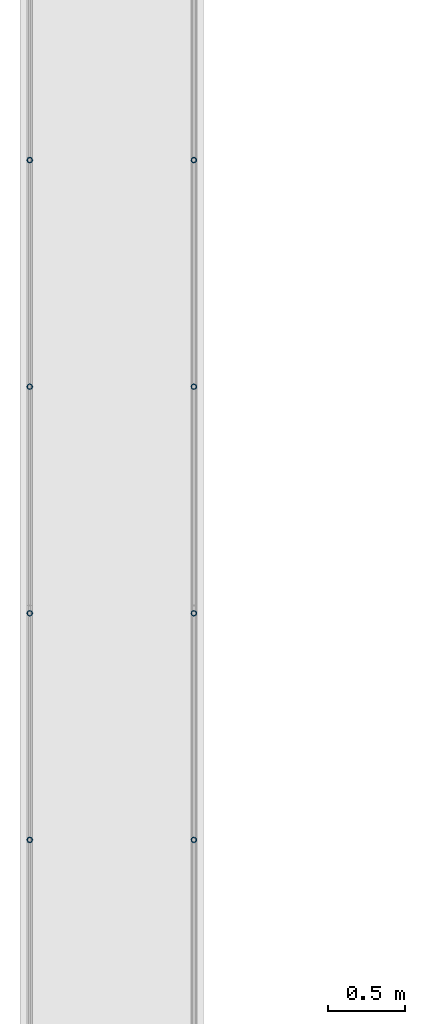
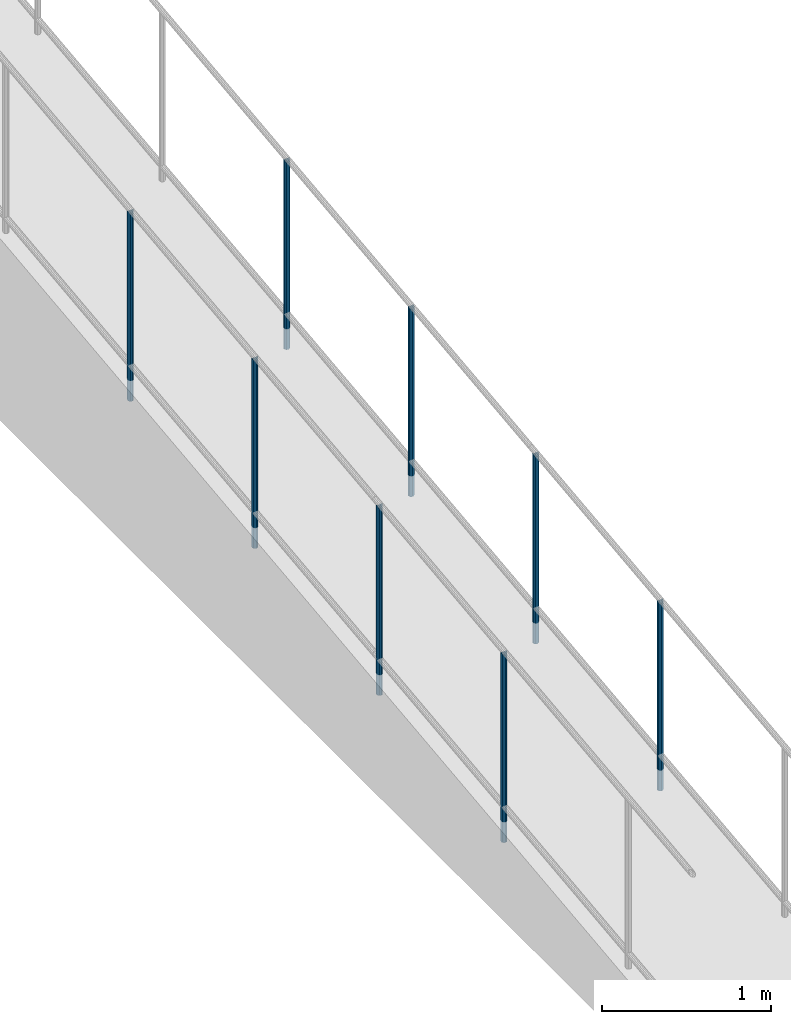
# One storey, part 874 of 1763: 8 columns, 4 elements without a shape of their own.
"""IFC2X3 building model written with IfcOpenShell, lengths in millimetres."""

from ifc_helpers import new_model, si_unit, frame, origin_with_axes, place, context, subcontext, project, spatial, faceted_brep, material, type_object, element, aggregate, save


model = new_model("IFC2X3")

# Units and contexts
model_context = context("Model", 3, precision=1e-05, world=origin_with_axes())
body_context = subcontext(model_context, "Body", "Model", "MODEL_VIEW")
ifc_project = project(units=[si_unit("LENGTHUNIT", "METRE", prefix="MILLI"), si_unit("AREAUNIT", "SQUARE_METRE"), si_unit("VOLUMEUNIT", "CUBIC_METRE"), si_unit("MASSUNIT", "GRAM", prefix="KILO"), si_unit("TIMEUNIT", "SECOND"), si_unit("PLANEANGLEUNIT", "RADIAN"), si_unit("SOLIDANGLEUNIT", "STERADIAN"), si_unit("THERMODYNAMICTEMPERATUREUNIT", "DEGREE_CELSIUS"), si_unit("LUMINOUSINTENSITYUNIT", "LUMEN")], contexts=[model_context])

# Site, building, storey
site_placement = place(None, origin_with_axes())
site = spatial("IfcSite", under=ifc_project, at=site_placement, CompositionType="ELEMENT")
building_placement = place(site_placement, origin_with_axes())
building = spatial("IfcBuilding", under=site, at=building_placement, Name="Undefined", CompositionType="ELEMENT")
storey_placement = place(building_placement, origin_with_axes())
storey = spatial("IfcBuildingStorey", under=building, at=storey_placement, Name="Undefined", CompositionType="ELEMENT", Elevation=0.0)

# Assembly, columns
assembly_1_placement = place(storey_placement, origin_with_axes())
assembly_1 = element("IfcElementAssembly", 1, at=assembly_1_placement, inside=storey, Name="GUARDRAIL", AssemblyPlace="NOTDEFINED", PredefinedType="RIGID_FRAME")
ifc_material = material(Name="STEEL/A513")
column_type = type_object("IfcColumnType", PredefinedType="NOTDEFINED")
column_1_placement = place(assembly_1_placement, frame((-97200.6527017878, -5416.76266955813, 4407.28954874992), z_axis=(0.0, -0.999999999989044, 4.68099999989136e-06), x_axis=(0.0, 4.68100000009712e-06, 0.999999999989044)))
column_1 = element("IfcColumn", 2, at=column_1_placement, type_object=column_type, material=ifc_material, Name="POST TUBE", context=body_context, shape_type="Brep", body=[
    faceted_brep([(1371.60074802696, 19.0500000000029, -4.95674612466246e-10), (1360.84881750874, 16.4977839420899, 9.52499999994143), (1363.03561091082, 16.4977839420899, -9.52500000005693), (1352.86103134268, -7.14375000000291, 12.3733379565128), (1350.71456778439, 0.0, 14.2874999999422), (1350.16786943387, 0.0, 19.0499999999411), (1353.02982084493, -9.52499999999418, 16.4977839420362), (1353.77662467995, -9.52499999999418, 9.99208795651248), (1353.77662467995, 9.52499999999418, 9.99208795651248), (1353.02982084493, 9.52499999999418, 16.4977839420362), (1352.86103134268, 7.14375000000291, 12.3733379565128), (1356.97063515909, 12.3733379565674, 7.14374999994197), (1359.71741517087, 14.2875000000058, -5.82076609134674e-11), (1358.61073021065, 12.3733379565674, -7.14375000005748), (1356.07065428797, 9.52499999999418, -9.99208795662707), (1356.81745812299, 9.52499999999418, -16.4977839421499), (1355.70175930123, 7.14375000000291, -12.3733379566265), (1353.99475788751, 0.0, -14.2875000000577), (1354.54145623803, 0.0, -19.0500000000566), (1355.70175930123, -7.14375000000291, -12.3733379566265), (1356.07065428797, -9.52499999999418, -9.99208795662707), (1356.81745812299, -9.52499999999418, -16.4977839421499), (1371.53068898859, -19.0500000000029, -0.00804413668356574), (1363.03561091082, -16.4977839420899, -9.52500000005693), (1360.84881750874, -16.4977839420899, 9.52499999994143), (1358.61073021064, -12.3733379565674, -7.14375000005748), (1359.71741517087, -14.2875000000058, -5.82076609134674e-11), (1356.97063515908, -12.3733379565674, 7.14374999994197), (0.0, -16.4977839420899, -9.52500000000146), (0.0, -9.52499999999418, -16.4977839420935), (1.45519152283669e-11, 1.81898940354586e-12, -19.0499999999993), (0.0, 9.52499999999418, -16.4977839420935), (0.0, 16.4977839420899, -9.52500000000146), (0.0, 19.0500000000029, 0.0), (0.0, 16.4977839420899, 9.52500000000146), (0.0, 9.52499999999418, 16.4977839420935), (1.45519152283669e-11, 1.81898940354586e-12, 19.0499999999993), (0.0, -9.52499999999418, 16.4977839420935), (0.0, -16.4977839420899, 9.52500000000146), (0.0, -19.0500000000029, 0.0), (0.0, -12.3733379565674, -7.14374999999927), (0.0, -7.14375000000291, -12.373337956571), (0.0, 0.0, -14.2874999999985), (0.0, 7.14375000000291, -12.373337956571), (0.0, 12.3733379565674, -7.14374999999927), (0.0, 14.2875000000058, 0.0), (0.0, 12.3733379565674, 7.14374999999927), (0.0, 7.14375000000291, 12.373337956571), (0.0, 0.0, 14.2874999999985), (0.0, -7.14375000000291, 12.373337956571), (0.0, -12.3733379565674, 7.14374999999927), (0.0, -14.2875000000058, 0.0)], [[[0, 1, 2]], [[3, 4, 5, 6, 7]], [[8, 9, 5, 4, 10]], [[2, 1, 9, 8, 11, 12, 13, 14, 15]], [[15, 14, 16, 17, 18]], [[18, 17, 19, 20, 21]], [[22, 23, 24]], [[21, 20, 25, 26, 27, 7, 6, 24, 23]], [[28, 29, 21, 23]], [[29, 30, 18, 21]], [[30, 31, 15, 18]], [[31, 32, 2, 15]], [[32, 33, 0, 2]], [[33, 34, 1, 0]], [[34, 35, 9, 1]], [[35, 36, 5, 9]], [[36, 37, 6, 5]], [[37, 38, 24, 6]], [[38, 39, 22, 24]], [[39, 28, 23, 22]], [[38, 37, 36, 35, 34, 33, 32, 31, 30, 29, 28, 39], [40, 41, 42, 43, 44, 45, 46, 47, 48, 49, 50, 51]], [[40, 51, 26, 25]], [[19, 41, 40, 25, 20]], [[42, 41, 19, 17]], [[43, 42, 17, 16]], [[44, 43, 16, 14, 13]], [[45, 44, 13, 12]], [[46, 45, 12, 11]], [[10, 47, 46, 11, 8]], [[48, 47, 10, 4]], [[49, 48, 4, 3]], [[50, 49, 3, 7, 27]], [[51, 50, 27, 26]]]),
])
column_2_placement = place(assembly_1_placement, frame((-97200.6527017878, -6889.96267103608, 4238.14864948887), z_axis=(0.0, -0.999999999989044, 4.68099999989136e-06), x_axis=(0.0, 4.68100000009712e-06, 0.999999999989044)))
column_2 = element("IfcColumn", 3, at=column_2_placement, type_object=column_type, material=ifc_material, Name="POST TUBE", context=body_context, shape_type="Brep", body=[
    faceted_brep([(1371.60074802696, 19.0500000000029, -4.95674612466246e-10), (1360.88493927643, 16.4977839420899, 9.52499999985503), (1363.07173256271, 16.4977839420899, -9.52500000014425), (1352.89715313297, -7.14375000000291, 12.3733379564264), (1350.75068958764, 0.0, 14.2874999998558), (1350.20399126607, 0.0, 19.0499999998547), (1353.06594265984, -9.52499999999418, 16.497783941948), (1353.81274645531, -9.52499999999418, 9.99208795642517), (1353.81274645531, 9.52499999999418, 9.99208795642517), (1353.06594265984, 9.52499999999418, 16.497783941948), (1352.89715313297, 7.14375000000291, 12.3733379564264), (1357.00675691517, 12.3733379565674, 7.14374999985466), (1359.7535368822, 14.2875000000058, -1.43700162880123e-10), (1358.64685187987, 12.3733379565674, -7.14375000014297), (1356.10677594185, 9.52499999999418, -9.99208795671348), (1356.85357973732, 9.52499999999418, -16.4977839422363), (1355.73788094108, 7.14375000000291, -12.3733379567129), (1354.03087951705, 0.0, -14.2875000001432), (1354.57757783861, 0.0, -19.050000000143), (1355.73788094107, -7.14375000000291, -12.3733379567129), (1356.10677594185, -9.52499999999418, -9.99208795671348), (1356.85357973732, -9.52499999999418, -16.4977839422363), (1371.56634088451, -19.0500000000029, -0.00395146479149844), (1363.07173256271, -16.4977839420899, -9.52500000014425), (1360.88493927643, -16.4977839420899, 9.52499999985503), (1358.64685187987, -12.3733379565674, -7.14375000014297), (1359.75353688219, -14.2875000000058, -1.43700162880123e-10), (1357.00675691516, -12.3733379565674, 7.14374999985466), (0.0, -16.4977839420899, -9.52500000000146), (0.0, -9.52499999999418, -16.4977839420935), (1.45519152283669e-11, 1.81898940354586e-12, -19.0499999999993), (0.0, 9.52499999999418, -16.4977839420935), (0.0, 16.4977839420899, -9.52500000000146), (0.0, 19.0500000000029, 0.0), (0.0, 16.4977839420899, 9.52500000000146), (0.0, 9.52499999999418, 16.4977839420935), (1.45519152283669e-11, 1.81898940354586e-12, 19.0499999999993), (0.0, -9.52499999999418, 16.4977839420935), (0.0, -16.4977839420899, 9.52500000000146), (0.0, -19.0500000000029, 0.0), (0.0, -12.3733379565674, -7.14374999999927), (0.0, -7.14375000000291, -12.373337956571), (0.0, 0.0, -14.2874999999985), (0.0, 7.14375000000291, -12.373337956571), (0.0, 12.3733379565674, -7.14374999999927), (0.0, 14.2875000000058, 0.0), (0.0, 12.3733379565674, 7.14374999999927), (0.0, 7.14375000000291, 12.373337956571), (0.0, 0.0, 14.2874999999985), (0.0, -7.14375000000291, 12.373337956571), (0.0, -12.3733379565674, 7.14374999999927), (0.0, -14.2875000000058, 0.0)], [[[0, 1, 2]], [[3, 4, 5, 6, 7]], [[8, 9, 5, 4, 10]], [[2, 1, 9, 8, 11, 12, 13, 14, 15]], [[15, 14, 16, 17, 18]], [[18, 17, 19, 20, 21]], [[22, 23, 24]], [[21, 20, 25, 26, 27, 7, 6, 24, 23]], [[28, 29, 21, 23]], [[29, 30, 18, 21]], [[30, 31, 15, 18]], [[31, 32, 2, 15]], [[32, 33, 0, 2]], [[33, 34, 1, 0]], [[34, 35, 9, 1]], [[35, 36, 5, 9]], [[36, 37, 6, 5]], [[37, 38, 24, 6]], [[38, 39, 22, 24]], [[39, 28, 23, 22]], [[38, 37, 36, 35, 34, 33, 32, 31, 30, 29, 28, 39], [40, 41, 42, 43, 44, 45, 46, 47, 48, 49, 50, 51]], [[40, 51, 26, 25]], [[19, 41, 40, 25, 20]], [[42, 41, 19, 17]], [[43, 42, 17, 16]], [[44, 43, 16, 14, 13]], [[45, 44, 13, 12]], [[46, 45, 12, 11]], [[10, 47, 46, 11, 8]], [[48, 47, 10, 4]], [[49, 48, 4, 3]], [[50, 49, 3, 7, 27]], [[51, 50, 27, 26]]]),
])
aggregate(assembly_1, [column_1, column_2])

assembly_2_placement = place(storey_placement, origin_with_axes())
assembly_2 = element("IfcElementAssembly", 4, at=assembly_2_placement, inside=storey, Name="GUARDRAIL", AssemblyPlace="NOTDEFINED", PredefinedType="RIGID_FRAME")
column_3_placement = place(assembly_2_placement, frame((-97200.6527017878, -8363.16267251402, 4069.00775022782), z_axis=(0.0, -0.999999999989044, 4.68099999989136e-06), x_axis=(0.0, 4.68100000009712e-06, 0.999999999989044)))
column_3 = element("IfcColumn", 5, at=column_3_placement, type_object=column_type, material=ifc_material, Name="POST TUBE", context=body_context, shape_type="Brep", body=[
    faceted_brep([(1371.60074802696, 19.0500000000029, -4.95674612466246e-10), (1360.91954353543, 16.4977839420899, 9.52499999992688), (1363.1068023618, 16.4977839420899, -9.52500000007285), (1352.93166657158, -7.14375000000291, 12.3733379564974), (1350.78515091293, 0.0, 14.2874999999276), (1350.23833620634, 0.0, 19.0499999999279), (1353.10035708436, -9.52499999999418, 16.4977839420208), (1353.84731986472, -9.52499999997963, 9.99208795651202), (1353.84731986473, 9.52500000000873, 9.99208795648292), (1353.10035708436, 9.52499999999418, 16.4977839420208), (1352.93166657157, 7.14375000000291, 12.3733379564974), (1357.04140787087, 12.3733379565674, 7.14374999992697), (1359.7883677507, 14.2875000000058, -7.27595761418343e-11), (1358.68185199063, 12.3733379565674, -7.14375000007294), (1356.14183772056, 9.52500000000873, -9.99208795662844), (1356.88880050093, 9.52499999999418, -16.4977839421663), (1355.77299913398, 7.14375000000291, -12.3733379566434), (1354.06603915248, 0.0, -14.2875000000727), (1354.61285385908, 0.0, -19.0500000000725), (1355.77299913399, -7.14375000000291, -12.3733379566434), (1356.14183772056, -9.52499999997963, -9.992087956658), (1356.88880050093, -9.52499999999418, -16.4977839421663), (1371.60075086449, -19.0499999999884, 1.21417542686686e-10), (1363.1068023618, -16.4977839420899, -9.52500000007285), (1360.91954353543, -16.4977839420899, 9.52499999992688), (1358.68185199066, -12.3733379565674, -7.14375000007294), (1359.78836775073, -14.2875000000058, -7.27595761418343e-11), (1357.0414078709, -12.3733379565674, 7.14374999992697), (0.0, -16.4977839420899, -9.52500000000146), (0.0, -9.52499999999418, -16.4977839420935), (1.45519152283669e-11, 1.81898940354586e-12, -19.0499999999993), (0.0, 9.52499999999418, -16.4977839420935), (0.0, 16.4977839420899, -9.52500000000146), (0.0, 19.0500000000029, 0.0), (0.0, 16.4977839420899, 9.52500000000146), (0.0, 9.52499999999418, 16.4977839420935), (1.45519152283669e-11, 1.81898940354586e-12, 19.0499999999993), (0.0, -9.52499999999418, 16.4977839420935), (0.0, -16.4977839420899, 9.52500000000146), (0.0, -19.0500000000029, 0.0), (0.0, -12.3733379565674, -7.14374999999927), (0.0, -7.14375000000291, -12.373337956571), (0.0, 0.0, -14.2874999999985), (0.0, 7.14375000000291, -12.373337956571), (0.0, 12.3733379565674, -7.14374999999927), (0.0, 14.2875000000058, 0.0), (0.0, 12.3733379565674, 7.14374999999927), (0.0, 7.14375000000291, 12.373337956571), (0.0, 0.0, 14.2874999999985), (0.0, -7.14375000000291, 12.373337956571), (0.0, -12.3733379565674, 7.14374999999927), (0.0, -14.2875000000058, 0.0)], [[[0, 1, 2]], [[3, 4, 5, 6, 7]], [[8, 9, 5, 4, 10]], [[2, 1, 9, 8, 11, 12, 13, 14, 15]], [[15, 14, 16, 17, 18]], [[18, 17, 19, 20, 21]], [[22, 23, 24]], [[21, 20, 25, 26, 27, 7, 6, 24, 23]], [[28, 29, 21, 23]], [[29, 30, 18, 21]], [[30, 31, 15, 18]], [[31, 32, 2, 15]], [[32, 33, 0, 2]], [[33, 34, 1, 0]], [[34, 35, 9, 1]], [[35, 36, 5, 9]], [[36, 37, 6, 5]], [[37, 38, 24, 6]], [[38, 39, 22, 24]], [[39, 28, 23, 22]], [[38, 37, 36, 35, 34, 33, 32, 31, 30, 29, 28, 39], [40, 41, 42, 43, 44, 45, 46, 47, 48, 49, 50, 51]], [[40, 51, 26, 25]], [[19, 41, 40, 25, 20]], [[42, 41, 19, 17]], [[43, 42, 17, 16]], [[44, 43, 16, 14, 13]], [[45, 44, 13, 12]], [[46, 45, 12, 11]], [[10, 47, 46, 11, 8]], [[48, 47, 10, 4]], [[49, 48, 4, 3]], [[50, 49, 3, 7, 27]], [[51, 50, 27, 26]]]),
])
column_4_placement = place(assembly_2_placement, frame((-97200.6527017878, -9836.36267399197, 3899.86685096677), z_axis=(0.0, -0.999999999989044, 4.68099999989136e-06), x_axis=(0.0, 4.68100000009712e-06, 0.999999999989044)))
column_4 = element("IfcColumn", 6, at=column_4_placement, type_object=column_type, material=ifc_material, Name="POST TUBE", context=body_context, shape_type="Brep", body=[
    faceted_brep([(1371.60074802696, 19.0500000000029, -4.95674612466246e-10), (1360.91954353543, 16.4977839420899, 9.52499999992688), (1363.1068023618, 16.4977839420899, -9.52500000007285), (1352.93166657158, -7.14375000000291, 12.3733379564974), (1350.78515091293, 0.0, 14.2874999999276), (1350.23833620634, 0.0, 19.0499999999279), (1353.10035708436, -9.52499999999418, 16.4977839420208), (1353.84731986472, -9.52499999997963, 9.99208795651202), (1353.84731986473, 9.52500000000873, 9.99208795648292), (1353.10035708436, 9.52499999999418, 16.4977839420208), (1352.93166657157, 7.14375000000291, 12.3733379564974), (1357.04140787087, 12.3733379565674, 7.14374999992697), (1359.7883677507, 14.2875000000058, -7.27595761418343e-11), (1358.68185199063, 12.3733379565674, -7.14375000007294), (1356.14183772056, 9.52500000000873, -9.99208795662844), (1356.88880050093, 9.52499999999418, -16.4977839421663), (1355.77299913398, 7.14375000000291, -12.3733379566434), (1354.06603915248, 0.0, -14.2875000000727), (1354.61285385908, 0.0, -19.0500000000725), (1355.77299913399, -7.14375000000291, -12.3733379566434), (1356.14183772056, -9.52499999997963, -9.992087956658), (1356.88880050093, -9.52499999999418, -16.4977839421663), (1371.60075086449, -19.0499999999884, 1.21417542686686e-10), (1363.1068023618, -16.4977839420899, -9.52500000007285), (1360.91954353543, -16.4977839420899, 9.52499999992688), (1358.68185199066, -12.3733379565674, -7.14375000007294), (1359.78836775073, -14.2875000000058, -7.27595761418343e-11), (1357.0414078709, -12.3733379565674, 7.14374999992697), (0.0, -16.4977839420899, -9.52500000000146), (0.0, -9.52499999999418, -16.4977839420935), (1.45519152283669e-11, 1.81898940354586e-12, -19.0499999999993), (0.0, 9.52499999999418, -16.4977839420935), (0.0, 16.4977839420899, -9.52500000000146), (0.0, 19.0500000000029, 0.0), (0.0, 16.4977839420899, 9.52500000000146), (0.0, 9.52499999999418, 16.4977839420935), (1.45519152283669e-11, 1.81898940354586e-12, 19.0499999999993), (0.0, -9.52499999999418, 16.4977839420935), (0.0, -16.4977839420899, 9.52500000000146), (0.0, -19.0500000000029, 0.0), (0.0, -12.3733379565674, -7.14374999999927), (0.0, -7.14375000000291, -12.373337956571), (0.0, 0.0, -14.2874999999985), (0.0, 7.14375000000291, -12.373337956571), (0.0, 12.3733379565674, -7.14374999999927), (0.0, 14.2875000000058, 0.0), (0.0, 12.3733379565674, 7.14374999999927), (0.0, 7.14375000000291, 12.373337956571), (0.0, 0.0, 14.2874999999985), (0.0, -7.14375000000291, 12.373337956571), (0.0, -12.3733379565674, 7.14374999999927), (0.0, -14.2875000000058, 0.0)], [[[0, 1, 2]], [[3, 4, 5, 6, 7]], [[8, 9, 5, 4, 10]], [[2, 1, 9, 8, 11, 12, 13, 14, 15]], [[15, 14, 16, 17, 18]], [[18, 17, 19, 20, 21]], [[22, 23, 24]], [[21, 20, 25, 26, 27, 7, 6, 24, 23]], [[28, 29, 21, 23]], [[29, 30, 18, 21]], [[30, 31, 15, 18]], [[31, 32, 2, 15]], [[32, 33, 0, 2]], [[33, 34, 1, 0]], [[34, 35, 9, 1]], [[35, 36, 5, 9]], [[36, 37, 6, 5]], [[37, 38, 24, 6]], [[38, 39, 22, 24]], [[39, 28, 23, 22]], [[38, 37, 36, 35, 34, 33, 32, 31, 30, 29, 28, 39], [40, 41, 42, 43, 44, 45, 46, 47, 48, 49, 50, 51]], [[40, 51, 26, 25]], [[19, 41, 40, 25, 20]], [[42, 41, 19, 17]], [[43, 42, 17, 16]], [[44, 43, 16, 14, 13]], [[45, 44, 13, 12]], [[46, 45, 12, 11]], [[10, 47, 46, 11, 8]], [[48, 47, 10, 4]], [[49, 48, 4, 3]], [[50, 49, 3, 7, 27]], [[51, 50, 27, 26]]]),
])
aggregate(assembly_2, [column_3, column_4])

assembly_3_placement = place(storey_placement, origin_with_axes())
assembly_3 = element("IfcElementAssembly", 7, at=assembly_3_placement, inside=storey, Name="GUARDRAIL", AssemblyPlace="NOTDEFINED", PredefinedType="RIGID_FRAME")
column_5_placement = place(assembly_3_placement, frame((-96133.8527017878, -5416.76266955813, 4407.28954874992), z_axis=(0.0, -0.999999999989044, 4.68099999989136e-06), x_axis=(0.0, 4.68100000009712e-06, 0.999999999989044)))
column_5 = element("IfcColumn", 8, at=column_5_placement, type_object=column_type, material=ifc_material, Name="POST TUBE", context=body_context, shape_type="Brep", body=[
    faceted_brep([(1371.60074802696, 19.0500000000029, -4.95674612466246e-10), (1360.84881750874, 16.4977839420899, 9.52499999994143), (1363.03561091082, 16.4977839420899, -9.52500000005693), (1352.86103134268, -7.14375000000291, 12.3733379565128), (1350.71456778439, 0.0, 14.2874999999422), (1350.16786943387, 0.0, 19.0499999999411), (1353.02982084493, -9.52499999999418, 16.4977839420362), (1353.77662467995, -9.52499999999418, 9.99208795651248), (1353.77662467995, 9.52499999999418, 9.99208795651248), (1353.02982084493, 9.52499999999418, 16.4977839420362), (1352.86103134268, 7.14375000000291, 12.3733379565128), (1356.97063515909, 12.3733379565674, 7.14374999994197), (1359.71741517087, 14.2875000000058, -5.82076609134674e-11), (1358.61073021065, 12.3733379565674, -7.14375000005748), (1356.07065428797, 9.52499999999418, -9.99208795662707), (1356.81745812299, 9.52499999999418, -16.4977839421499), (1355.70175930123, 7.14375000000291, -12.3733379566265), (1353.99475788751, 0.0, -14.2875000000577), (1354.54145623803, 0.0, -19.0500000000566), (1355.70175930123, -7.14375000000291, -12.3733379566265), (1356.07065428797, -9.52499999999418, -9.99208795662707), (1356.81745812299, -9.52499999999418, -16.4977839421499), (1371.53068898859, -19.0500000000029, -0.00804413668356574), (1363.03561091082, -16.4977839420899, -9.52500000005693), (1360.84881750874, -16.4977839420899, 9.52499999994143), (1358.61073021064, -12.3733379565674, -7.14375000005748), (1359.71741517087, -14.2875000000058, -5.82076609134674e-11), (1356.97063515908, -12.3733379565674, 7.14374999994197), (0.0, -16.4977839420899, -9.52500000000146), (0.0, -9.52499999999418, -16.4977839420935), (1.45519152283669e-11, 1.81898940354586e-12, -19.0499999999993), (0.0, 9.52499999999418, -16.4977839420935), (0.0, 16.4977839420899, -9.52500000000146), (0.0, 19.0500000000029, 0.0), (0.0, 16.4977839420899, 9.52500000000146), (0.0, 9.52499999999418, 16.4977839420935), (1.45519152283669e-11, 1.81898940354586e-12, 19.0499999999993), (0.0, -9.52499999999418, 16.4977839420935), (0.0, -16.4977839420899, 9.52500000000146), (0.0, -19.0500000000029, 0.0), (0.0, -12.3733379565674, -7.14374999999927), (0.0, -7.14375000000291, -12.373337956571), (0.0, 0.0, -14.2874999999985), (0.0, 7.14375000000291, -12.373337956571), (0.0, 12.3733379565674, -7.14374999999927), (0.0, 14.2875000000058, 0.0), (0.0, 12.3733379565674, 7.14374999999927), (0.0, 7.14375000000291, 12.373337956571), (0.0, 0.0, 14.2874999999985), (0.0, -7.14375000000291, 12.373337956571), (0.0, -12.3733379565674, 7.14374999999927), (0.0, -14.2875000000058, 0.0)], [[[0, 1, 2]], [[3, 4, 5, 6, 7]], [[8, 9, 5, 4, 10]], [[2, 1, 9, 8, 11, 12, 13, 14, 15]], [[15, 14, 16, 17, 18]], [[18, 17, 19, 20, 21]], [[22, 23, 24]], [[21, 20, 25, 26, 27, 7, 6, 24, 23]], [[28, 29, 21, 23]], [[29, 30, 18, 21]], [[30, 31, 15, 18]], [[31, 32, 2, 15]], [[32, 33, 0, 2]], [[33, 34, 1, 0]], [[34, 35, 9, 1]], [[35, 36, 5, 9]], [[36, 37, 6, 5]], [[37, 38, 24, 6]], [[38, 39, 22, 24]], [[39, 28, 23, 22]], [[38, 37, 36, 35, 34, 33, 32, 31, 30, 29, 28, 39], [40, 41, 42, 43, 44, 45, 46, 47, 48, 49, 50, 51]], [[40, 51, 26, 25]], [[19, 41, 40, 25, 20]], [[42, 41, 19, 17]], [[43, 42, 17, 16]], [[44, 43, 16, 14, 13]], [[45, 44, 13, 12]], [[46, 45, 12, 11]], [[10, 47, 46, 11, 8]], [[48, 47, 10, 4]], [[49, 48, 4, 3]], [[50, 49, 3, 7, 27]], [[51, 50, 27, 26]]]),
])
column_6_placement = place(assembly_3_placement, frame((-96133.8527017878, -6889.96267103608, 4238.14864948887), z_axis=(0.0, -0.999999999989044, 4.68099999989136e-06), x_axis=(0.0, 4.68100000009712e-06, 0.999999999989044)))
column_6 = element("IfcColumn", 9, at=column_6_placement, type_object=column_type, material=ifc_material, Name="POST TUBE", context=body_context, shape_type="Brep", body=[
    faceted_brep([(1371.60074802696, 19.0500000000029, -4.95674612466246e-10), (1360.88493927643, 16.4977839420899, 9.52499999985503), (1363.07173256271, 16.4977839420899, -9.52500000014425), (1352.89715313297, -7.14375000000291, 12.3733379564264), (1350.75068958764, 0.0, 14.2874999998558), (1350.20399126607, 0.0, 19.0499999998547), (1353.06594265984, -9.52499999999418, 16.497783941948), (1353.81274645531, -9.52499999999418, 9.99208795642517), (1353.81274645531, 9.52499999999418, 9.99208795642517), (1353.06594265984, 9.52499999999418, 16.497783941948), (1352.89715313297, 7.14375000000291, 12.3733379564264), (1357.00675691517, 12.3733379565674, 7.14374999985466), (1359.7535368822, 14.2875000000058, -1.43700162880123e-10), (1358.64685187987, 12.3733379565674, -7.14375000014297), (1356.10677594185, 9.52499999999418, -9.99208795671348), (1356.85357973732, 9.52499999999418, -16.4977839422363), (1355.73788094108, 7.14375000000291, -12.3733379567129), (1354.03087951705, 0.0, -14.2875000001432), (1354.57757783861, 0.0, -19.050000000143), (1355.73788094107, -7.14375000000291, -12.3733379567129), (1356.10677594185, -9.52499999999418, -9.99208795671348), (1356.85357973732, -9.52499999999418, -16.4977839422363), (1371.56634088451, -19.0500000000029, -0.00395146479149844), (1363.07173256271, -16.4977839420899, -9.52500000014425), (1360.88493927643, -16.4977839420899, 9.52499999985503), (1358.64685187987, -12.3733379565674, -7.14375000014297), (1359.75353688219, -14.2875000000058, -1.43700162880123e-10), (1357.00675691516, -12.3733379565674, 7.14374999985466), (0.0, -16.4977839420899, -9.52500000000146), (0.0, -9.52499999999418, -16.4977839420935), (1.45519152283669e-11, 1.81898940354586e-12, -19.0499999999993), (0.0, 9.52499999999418, -16.4977839420935), (0.0, 16.4977839420899, -9.52500000000146), (0.0, 19.0500000000029, 0.0), (0.0, 16.4977839420899, 9.52500000000146), (0.0, 9.52499999999418, 16.4977839420935), (1.45519152283669e-11, 1.81898940354586e-12, 19.0499999999993), (0.0, -9.52499999999418, 16.4977839420935), (0.0, -16.4977839420899, 9.52500000000146), (0.0, -19.0500000000029, 0.0), (0.0, -12.3733379565674, -7.14374999999927), (0.0, -7.14375000000291, -12.373337956571), (0.0, 0.0, -14.2874999999985), (0.0, 7.14375000000291, -12.373337956571), (0.0, 12.3733379565674, -7.14374999999927), (0.0, 14.2875000000058, 0.0), (0.0, 12.3733379565674, 7.14374999999927), (0.0, 7.14375000000291, 12.373337956571), (0.0, 0.0, 14.2874999999985), (0.0, -7.14375000000291, 12.373337956571), (0.0, -12.3733379565674, 7.14374999999927), (0.0, -14.2875000000058, 0.0)], [[[0, 1, 2]], [[3, 4, 5, 6, 7]], [[8, 9, 5, 4, 10]], [[2, 1, 9, 8, 11, 12, 13, 14, 15]], [[15, 14, 16, 17, 18]], [[18, 17, 19, 20, 21]], [[22, 23, 24]], [[21, 20, 25, 26, 27, 7, 6, 24, 23]], [[28, 29, 21, 23]], [[29, 30, 18, 21]], [[30, 31, 15, 18]], [[31, 32, 2, 15]], [[32, 33, 0, 2]], [[33, 34, 1, 0]], [[34, 35, 9, 1]], [[35, 36, 5, 9]], [[36, 37, 6, 5]], [[37, 38, 24, 6]], [[38, 39, 22, 24]], [[39, 28, 23, 22]], [[38, 37, 36, 35, 34, 33, 32, 31, 30, 29, 28, 39], [40, 41, 42, 43, 44, 45, 46, 47, 48, 49, 50, 51]], [[40, 51, 26, 25]], [[19, 41, 40, 25, 20]], [[42, 41, 19, 17]], [[43, 42, 17, 16]], [[44, 43, 16, 14, 13]], [[45, 44, 13, 12]], [[46, 45, 12, 11]], [[10, 47, 46, 11, 8]], [[48, 47, 10, 4]], [[49, 48, 4, 3]], [[50, 49, 3, 7, 27]], [[51, 50, 27, 26]]]),
])
aggregate(assembly_3, [column_5, column_6])

assembly_4_placement = place(storey_placement, origin_with_axes())
assembly_4 = element("IfcElementAssembly", 10, at=assembly_4_placement, inside=storey, Name="GUARDRAIL", AssemblyPlace="NOTDEFINED", PredefinedType="RIGID_FRAME")
column_7_placement = place(assembly_4_placement, frame((-96133.8527017878, -8363.16267251402, 4069.00775022782), z_axis=(0.0, -0.999999999989044, 4.68099999989136e-06), x_axis=(0.0, 4.68100000009712e-06, 0.999999999989044)))
column_7 = element("IfcColumn", 11, at=column_7_placement, type_object=column_type, material=ifc_material, Name="POST TUBE", context=body_context, shape_type="Brep", body=[
    faceted_brep([(1371.60074802696, 19.0500000000029, -4.95674612466246e-10), (1360.91954353543, 16.4977839420899, 9.52499999992688), (1363.1068023618, 16.4977839420899, -9.52500000007285), (1352.93166657158, -7.14375000000291, 12.3733379564974), (1350.78515091293, 0.0, 14.2874999999276), (1350.23833620634, 0.0, 19.0499999999279), (1353.10035708436, -9.52499999999418, 16.4977839420208), (1353.84731986472, -9.52499999997963, 9.99208795651202), (1353.84731986473, 9.52500000000873, 9.99208795648292), (1353.10035708436, 9.52499999999418, 16.4977839420208), (1352.93166657157, 7.14375000000291, 12.3733379564974), (1357.04140787087, 12.3733379565674, 7.14374999992697), (1359.7883677507, 14.2875000000058, -7.27595761418343e-11), (1358.68185199063, 12.3733379565674, -7.14375000007294), (1356.14183772056, 9.52500000000873, -9.99208795662844), (1356.88880050093, 9.52499999999418, -16.4977839421663), (1355.77299913398, 7.14375000000291, -12.3733379566434), (1354.06603915248, 0.0, -14.2875000000727), (1354.61285385908, 0.0, -19.0500000000725), (1355.77299913399, -7.14375000000291, -12.3733379566434), (1356.14183772056, -9.52499999997963, -9.992087956658), (1356.88880050093, -9.52499999999418, -16.4977839421663), (1371.60075086449, -19.0499999999884, 1.21417542686686e-10), (1363.1068023618, -16.4977839420899, -9.52500000007285), (1360.91954353543, -16.4977839420899, 9.52499999992688), (1358.68185199066, -12.3733379565674, -7.14375000007294), (1359.78836775073, -14.2875000000058, -7.27595761418343e-11), (1357.0414078709, -12.3733379565674, 7.14374999992697), (0.0, -16.4977839420899, -9.52500000000146), (0.0, -9.52499999999418, -16.4977839420935), (1.45519152283669e-11, 1.81898940354586e-12, -19.0499999999993), (0.0, 9.52499999999418, -16.4977839420935), (0.0, 16.4977839420899, -9.52500000000146), (0.0, 19.0500000000029, 0.0), (0.0, 16.4977839420899, 9.52500000000146), (0.0, 9.52499999999418, 16.4977839420935), (1.45519152283669e-11, 1.81898940354586e-12, 19.0499999999993), (0.0, -9.52499999999418, 16.4977839420935), (0.0, -16.4977839420899, 9.52500000000146), (0.0, -19.0500000000029, 0.0), (0.0, -12.3733379565674, -7.14374999999927), (0.0, -7.14375000000291, -12.373337956571), (0.0, 0.0, -14.2874999999985), (0.0, 7.14375000000291, -12.373337956571), (0.0, 12.3733379565674, -7.14374999999927), (0.0, 14.2875000000058, 0.0), (0.0, 12.3733379565674, 7.14374999999927), (0.0, 7.14375000000291, 12.373337956571), (0.0, 0.0, 14.2874999999985), (0.0, -7.14375000000291, 12.373337956571), (0.0, -12.3733379565674, 7.14374999999927), (0.0, -14.2875000000058, 0.0)], [[[0, 1, 2]], [[3, 4, 5, 6, 7]], [[8, 9, 5, 4, 10]], [[2, 1, 9, 8, 11, 12, 13, 14, 15]], [[15, 14, 16, 17, 18]], [[18, 17, 19, 20, 21]], [[22, 23, 24]], [[21, 20, 25, 26, 27, 7, 6, 24, 23]], [[28, 29, 21, 23]], [[29, 30, 18, 21]], [[30, 31, 15, 18]], [[31, 32, 2, 15]], [[32, 33, 0, 2]], [[33, 34, 1, 0]], [[34, 35, 9, 1]], [[35, 36, 5, 9]], [[36, 37, 6, 5]], [[37, 38, 24, 6]], [[38, 39, 22, 24]], [[39, 28, 23, 22]], [[38, 37, 36, 35, 34, 33, 32, 31, 30, 29, 28, 39], [40, 41, 42, 43, 44, 45, 46, 47, 48, 49, 50, 51]], [[40, 51, 26, 25]], [[19, 41, 40, 25, 20]], [[42, 41, 19, 17]], [[43, 42, 17, 16]], [[44, 43, 16, 14, 13]], [[45, 44, 13, 12]], [[46, 45, 12, 11]], [[10, 47, 46, 11, 8]], [[48, 47, 10, 4]], [[49, 48, 4, 3]], [[50, 49, 3, 7, 27]], [[51, 50, 27, 26]]]),
])
column_8_placement = place(assembly_4_placement, frame((-96133.8527017878, -9836.36267399197, 3899.86685096677), z_axis=(0.0, -0.999999999989044, 4.68099999989136e-06), x_axis=(0.0, 4.68100000009712e-06, 0.999999999989044)))
column_8 = element("IfcColumn", 12, at=column_8_placement, type_object=column_type, material=ifc_material, Name="POST TUBE", context=body_context, shape_type="Brep", body=[
    faceted_brep([(1371.60074802696, 19.0500000000029, -4.95674612466246e-10), (1360.91954353543, 16.4977839420899, 9.52499999992688), (1363.1068023618, 16.4977839420899, -9.52500000007285), (1352.93166657158, -7.14375000000291, 12.3733379564974), (1350.78515091293, 0.0, 14.2874999999276), (1350.23833620634, 0.0, 19.0499999999279), (1353.10035708436, -9.52499999999418, 16.4977839420208), (1353.84731986472, -9.52499999997963, 9.99208795651202), (1353.84731986473, 9.52500000000873, 9.99208795648292), (1353.10035708436, 9.52499999999418, 16.4977839420208), (1352.93166657157, 7.14375000000291, 12.3733379564974), (1357.04140787087, 12.3733379565674, 7.14374999992697), (1359.7883677507, 14.2875000000058, -7.27595761418343e-11), (1358.68185199063, 12.3733379565674, -7.14375000007294), (1356.14183772056, 9.52500000000873, -9.99208795662844), (1356.88880050093, 9.52499999999418, -16.4977839421663), (1355.77299913398, 7.14375000000291, -12.3733379566434), (1354.06603915248, 0.0, -14.2875000000727), (1354.61285385908, 0.0, -19.0500000000725), (1355.77299913399, -7.14375000000291, -12.3733379566434), (1356.14183772056, -9.52499999997963, -9.992087956658), (1356.88880050093, -9.52499999999418, -16.4977839421663), (1371.60075086449, -19.0499999999884, 1.21417542686686e-10), (1363.1068023618, -16.4977839420899, -9.52500000007285), (1360.91954353543, -16.4977839420899, 9.52499999992688), (1358.68185199066, -12.3733379565674, -7.14375000007294), (1359.78836775073, -14.2875000000058, -7.27595761418343e-11), (1357.0414078709, -12.3733379565674, 7.14374999992697), (0.0, -16.4977839420899, -9.52500000000146), (0.0, -9.52499999999418, -16.4977839420935), (1.45519152283669e-11, 1.81898940354586e-12, -19.0499999999993), (0.0, 9.52499999999418, -16.4977839420935), (0.0, 16.4977839420899, -9.52500000000146), (0.0, 19.0500000000029, 0.0), (0.0, 16.4977839420899, 9.52500000000146), (0.0, 9.52499999999418, 16.4977839420935), (1.45519152283669e-11, 1.81898940354586e-12, 19.0499999999993), (0.0, -9.52499999999418, 16.4977839420935), (0.0, -16.4977839420899, 9.52500000000146), (0.0, -19.0500000000029, 0.0), (0.0, -12.3733379565674, -7.14374999999927), (0.0, -7.14375000000291, -12.373337956571), (0.0, 0.0, -14.2874999999985), (0.0, 7.14375000000291, -12.373337956571), (0.0, 12.3733379565674, -7.14374999999927), (0.0, 14.2875000000058, 0.0), (0.0, 12.3733379565674, 7.14374999999927), (0.0, 7.14375000000291, 12.373337956571), (0.0, 0.0, 14.2874999999985), (0.0, -7.14375000000291, 12.373337956571), (0.0, -12.3733379565674, 7.14374999999927), (0.0, -14.2875000000058, 0.0)], [[[0, 1, 2]], [[3, 4, 5, 6, 7]], [[8, 9, 5, 4, 10]], [[2, 1, 9, 8, 11, 12, 13, 14, 15]], [[15, 14, 16, 17, 18]], [[18, 17, 19, 20, 21]], [[22, 23, 24]], [[21, 20, 25, 26, 27, 7, 6, 24, 23]], [[28, 29, 21, 23]], [[29, 30, 18, 21]], [[30, 31, 15, 18]], [[31, 32, 2, 15]], [[32, 33, 0, 2]], [[33, 34, 1, 0]], [[34, 35, 9, 1]], [[35, 36, 5, 9]], [[36, 37, 6, 5]], [[37, 38, 24, 6]], [[38, 39, 22, 24]], [[39, 28, 23, 22]], [[38, 37, 36, 35, 34, 33, 32, 31, 30, 29, 28, 39], [40, 41, 42, 43, 44, 45, 46, 47, 48, 49, 50, 51]], [[40, 51, 26, 25]], [[19, 41, 40, 25, 20]], [[42, 41, 19, 17]], [[43, 42, 17, 16]], [[44, 43, 16, 14, 13]], [[45, 44, 13, 12]], [[46, 45, 12, 11]], [[10, 47, 46, 11, 8]], [[48, 47, 10, 4]], [[49, 48, 4, 3]], [[50, 49, 3, 7, 27]], [[51, 50, 27, 26]]]),
])
aggregate(assembly_4, [column_7, column_8])

save(model, "model.ifc")
